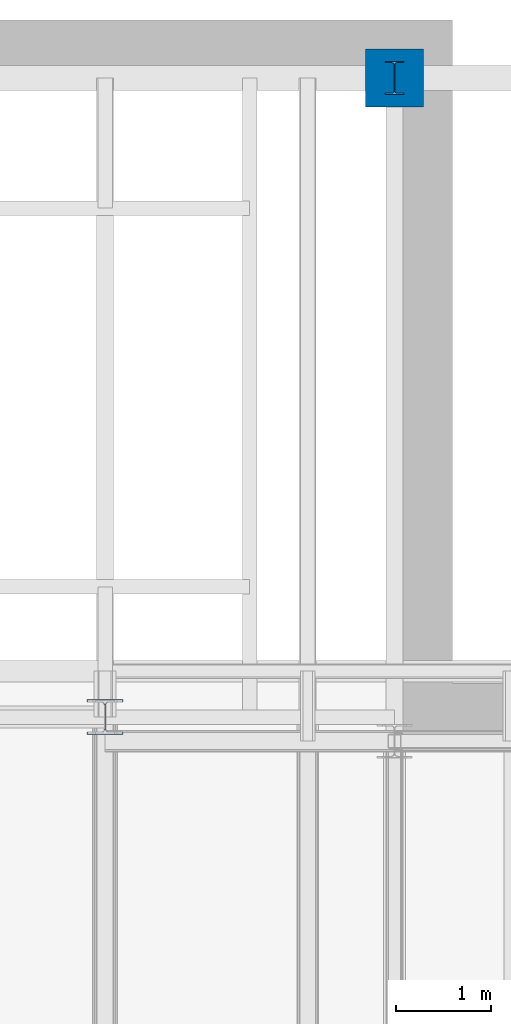
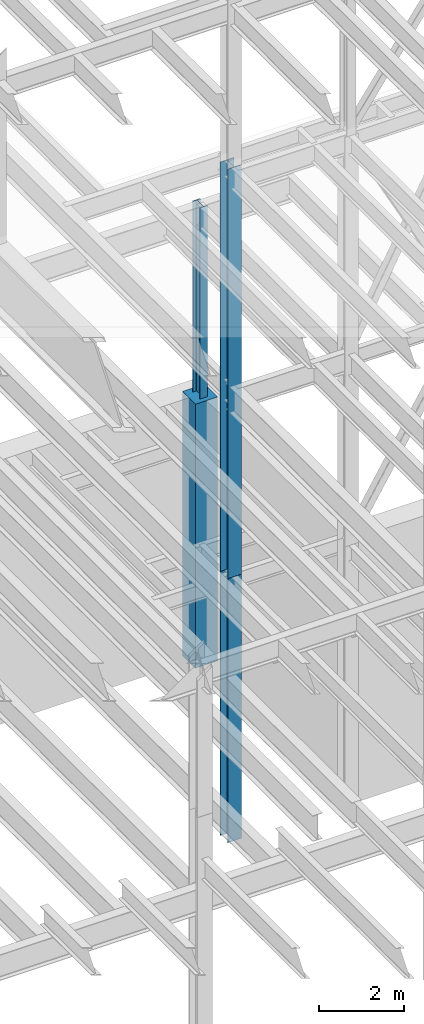
# One storey, part 69 of 150: 4 columns.
"""IFC2X3 building model written with IfcOpenShell, lengths in millimetres."""

from ifc_helpers import new_model, si_unit, frame, origin_with_axes, origin_2d_with_axis, place, context, subcontext, project, spatial, rectangle, i_section, extrude, material, type_object, element, save


model = new_model("IFC2X3")

# Units and contexts
model_context = context("Model", 3, precision=1e-05, world=origin_with_axes())
body_context = subcontext(model_context, "Body", "Model", "MODEL_VIEW")
ifc_project = project(units=[si_unit("LENGTHUNIT", "METRE", prefix="MILLI"), si_unit("AREAUNIT", "SQUARE_METRE"), si_unit("VOLUMEUNIT", "CUBIC_METRE"), si_unit("MASSUNIT", "GRAM", prefix="KILO"), si_unit("TIMEUNIT", "SECOND"), si_unit("PLANEANGLEUNIT", "RADIAN"), si_unit("SOLIDANGLEUNIT", "STERADIAN"), si_unit("THERMODYNAMICTEMPERATUREUNIT", "DEGREE_CELSIUS"), si_unit("LUMINOUSINTENSITYUNIT", "LUMEN")], contexts=[model_context])

# Site, building, storey
site_placement = place(None, origin_with_axes())
site = spatial("IfcSite", under=ifc_project, at=site_placement, CompositionType="ELEMENT")
building_placement = place(site_placement, origin_with_axes())
building = spatial("IfcBuilding", under=site, at=building_placement, Name="Undefined", CompositionType="ELEMENT")
storey_placement = place(building_placement, origin_with_axes())
storey = spatial("IfcBuildingStorey", under=building, at=storey_placement, Name="Undefined", CompositionType="ELEMENT", Elevation=0.0)

# Columns
ifc_material_1 = material(Name="STEEL/A992")
column_type_1 = type_object("IfcColumnType", Name="W14X43", PredefinedType="NOTDEFINED")
column_1_placement = place(storey_placement, frame((53238.4, 38862.0, 22707.6), z_axis=(0.0, 0.0, 1.0), x_axis=(1.0, 0.0, 0.0)))
element("IfcColumn", 1, at=column_1_placement, inside=storey, type_object=column_type_1, material=ifc_material_1, Name="COLUMN", ObjectType="W14X43", context=body_context, shape_type="SweptSolid", body=[
    extrude(i_section(OverallWidth=203.2, OverallDepth=346.075, WebThickness=7.9375, FlangeThickness=13.462, FilletRadius=21.4629, at=origin_2d_with_axis()), frame((0.0, 0.0, 6578.60000000001), z_axis=(0.0, 0.0, -1.0), x_axis=(-1.0, 0.0, 0.0)), (0.0, 0.0, 1.0), 6578.60000000001),
])
column_type_2 = type_object("IfcColumnType", Name="W14X132", PredefinedType="NOTDEFINED")
column_2_placement = place(storey_placement, frame((50190.4, 32131.0, 16154.4), z_axis=(0.0, 0.0, 1.0), x_axis=(1.0, 0.0, 0.0)))
element("IfcColumn", 2, at=column_2_placement, inside=storey, type_object=column_type_2, material=ifc_material_1, Name="COLUMN", ObjectType="W14X132", context=body_context, shape_type="SweptSolid", body=[
    extrude(i_section(OverallWidth=374.65, OverallDepth=371.475, WebThickness=15.875, FlangeThickness=26.162, FilletRadius=32.5755, at=origin_2d_with_axis()), frame((0.0, 0.0, 7620.0), z_axis=(0.0, 0.0, -1.0), x_axis=(-1.0, 0.0, 0.0)), (0.0, 0.0, 1.0), 7620.0),
])
column_type_3 = type_object("IfcColumnType", Name="W14X109", PredefinedType="NOTDEFINED")
column_3_placement = place(storey_placement, frame((50190.4, 32131.0, 23774.4), z_axis=(0.0, 0.0, 1.0), x_axis=(1.0, 0.0, 0.0)))
element("IfcColumn", 3, at=column_3_placement, inside=storey, type_object=column_type_3, material=ifc_material_1, Name="COLUMN", ObjectType="W14X109", context=body_context, shape_type="SweptSolid", body=[
    extrude(i_section(OverallWidth=370.84, OverallDepth=365.125, WebThickness=12.6999, FlangeThickness=21.844, FilletRadius=33.7184, at=origin_2d_with_axis()), frame((0.0, 0.0, 11811.0), z_axis=(0.0, 0.0, -1.0), x_axis=(-1.0, 0.0, 0.0)), (0.0, 0.0, 1.0), 11811.0),
])
ifc_material_2 = material(Name="CONCRETE/5000")
column_type_4 = type_object("IfcColumnType", PredefinedType="NOTDEFINED")
column_4_placement = place(storey_placement, frame((53238.4, 38862.0, 16154.4), z_axis=(0.0, 0.0, 1.0), x_axis=(1.0, 0.0, 0.0)))
element("IfcColumn", 4, at=column_4_placement, inside=storey, type_object=column_type_4, material=ifc_material_2, Name="COLUMN", context=body_context, shape_type="SweptSolid", body=[
    extrude(rectangle(XDim=609.6, YDim=609.6, at=origin_2d_with_axis()), frame((0.0, 0.0, 7620.0), z_axis=(0.0, 0.0, -1.0), x_axis=(0.0, -1.0, 0.0)), (0.0, 0.0, 1.0), 7620.0),
])

save(model, "model.ifc")
